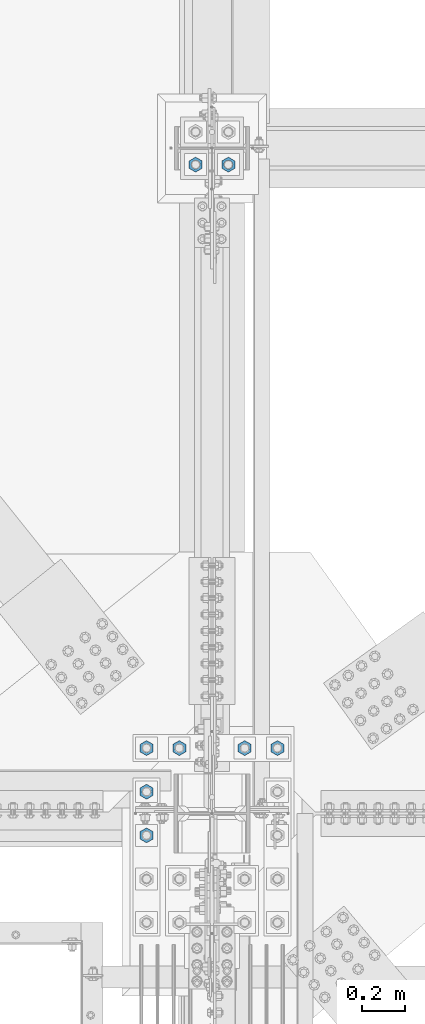
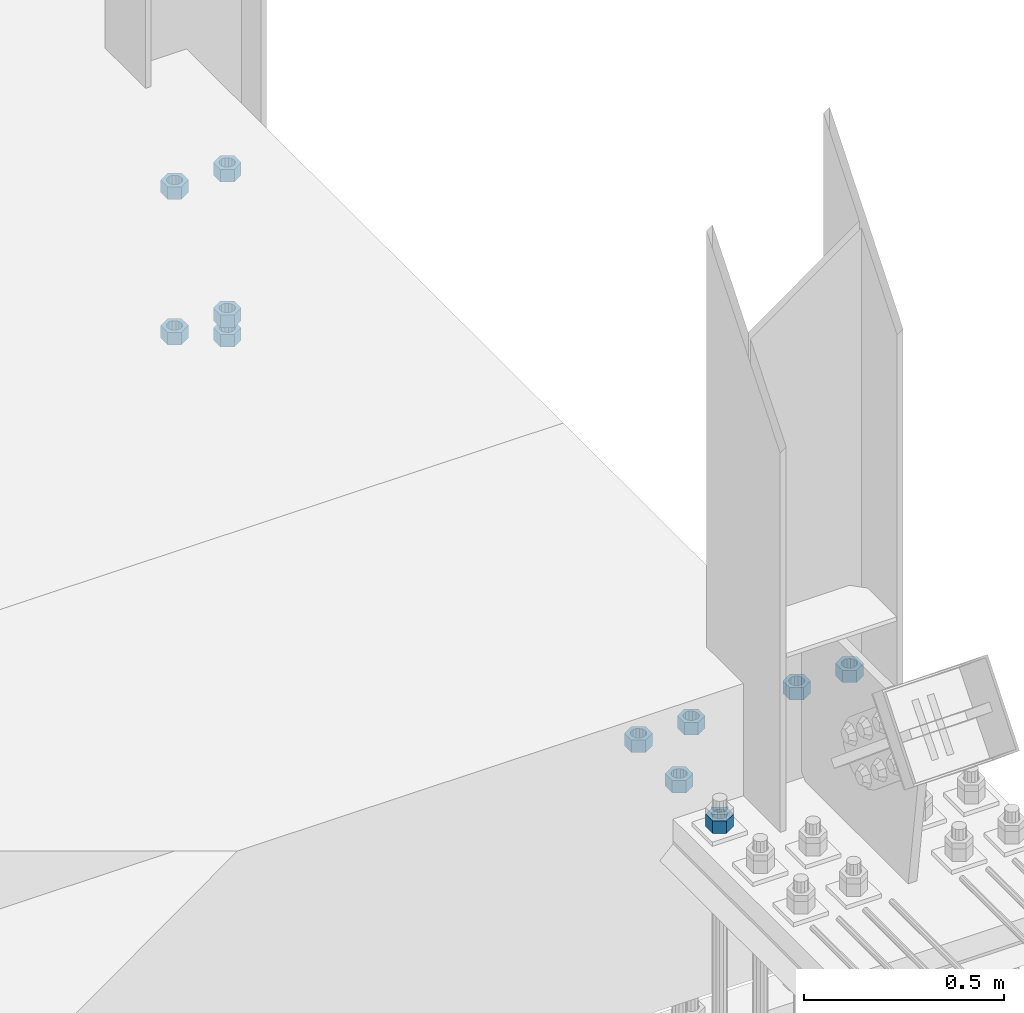
# One storey, part 1671 of 3843: 11 columns, 2 elements without a shape of their own.
"""IFC2X3 building model written with IfcOpenShell, lengths in millimetres."""

from ifc_helpers import new_model, si_unit, frame, origin_with_axes, place, context, subcontext, project, spatial, faceted_brep, material, type_object, element, aggregate, save


model = new_model("IFC2X3")

# Units and contexts
model_context = context("Model", 3, precision=1e-05, world=origin_with_axes())
body_context = subcontext(model_context, "Body", "Model", "MODEL_VIEW")
ifc_project = project(units=[si_unit("LENGTHUNIT", "METRE", prefix="MILLI"), si_unit("AREAUNIT", "SQUARE_METRE"), si_unit("VOLUMEUNIT", "CUBIC_METRE"), si_unit("MASSUNIT", "GRAM", prefix="KILO"), si_unit("TIMEUNIT", "SECOND"), si_unit("PLANEANGLEUNIT", "RADIAN"), si_unit("SOLIDANGLEUNIT", "STERADIAN"), si_unit("THERMODYNAMICTEMPERATUREUNIT", "DEGREE_CELSIUS"), si_unit("LUMINOUSINTENSITYUNIT", "LUMEN")], contexts=[model_context])

# Site, building, storey
site_placement = place(None, origin_with_axes())
site = spatial("IfcSite", under=ifc_project, at=site_placement, CompositionType="ELEMENT")
building_placement = place(site_placement, origin_with_axes())
building = spatial("IfcBuilding", under=site, at=building_placement, Name="Undefined", CompositionType="ELEMENT")
storey_placement = place(building_placement, origin_with_axes())
storey = spatial("IfcBuildingStorey", under=building, at=storey_placement, Name="Undefined", CompositionType="ELEMENT", Elevation=0.0)

# Assembly, columns
assembly_1_placement = place(storey_placement, origin_with_axes())
assembly_1 = element("IfcElementAssembly", 1, at=assembly_1_placement, inside=storey, Name="TEMPLATE", AssemblyPlace="NOTDEFINED", PredefinedType="RIGID_FRAME")
ifc_material_1 = material(Name="STEEL/A36")
column_type = type_object("IfcColumnType", Name="1-1/2_HEAVY_HEX_NUT", PredefinedType="NOTDEFINED")
column_1_placement = place(assembly_1_placement, frame((77089.0, 28638.5, 29705.3), z_axis=(1.0, 0.0, 0.0), x_axis=(0.0, 0.0, -1.0)))
column_1 = element("IfcColumn", 2, at=column_1_placement, type_object=column_type, material=ifc_material_1, Name="NUT", ObjectType="1-1/2_HEAVY_HEX_NUT", context=body_context, shape_type="Brep", body=[
    faceted_brep([(0.0, -34.9199981689453, 0.0), (0.0, -17.4599990844727, -30.25), (38.0999999999985, -17.4599990844727, -30.25), (38.0999999999985, -34.9199981689453, 0.0), (0.0, 17.4599990844727, -30.25), (38.0999999999985, 17.4599990844727, -30.25), (0.0, 34.9199981689453, 0.0), (38.0999999999985, 34.9199981689453, 0.0), (0.0, 17.4599990844727, 30.25), (38.0999999999985, 17.4599990844727, 30.25), (0.0, -17.4599990844727, 30.25), (38.0999999999985, -17.4599990844727, 30.25), (0.0, 0.0, 20.6399993896484), (0.0, 8.9553601105581, 18.5959968835959), (38.0999999999985, 8.9553601105581, 18.5959968835959), (38.0999999999985, 0.0, 20.6399993896484), (0.0, 16.1370013209525, 12.8688291298167), (38.0999999999985, 16.1370013209525, 12.8688291298167), (0.0, 20.1225115123816, 4.59283194104501), (38.0999999999985, 20.1225115123816, 4.59283194104501), (0.0, 20.1225115123816, -4.59283194104501), (38.0999999999985, 20.1225115123816, -4.59283194104501), (0.0, 16.1370013209525, -12.8688291298167), (38.0999999999985, 16.1370013209525, -12.8688291298167), (0.0, 8.9553601105581, -18.5959968835959), (38.0999999999985, 8.9553601105581, -18.5959968835959), (0.0, 0.0, -20.6399993896484), (38.0999999999985, 0.0, -20.6399993896484), (0.0, -8.9553601105581, -18.5959968835959), (38.0999999999985, -8.9553601105581, -18.5959968835959), (0.0, -16.1370013209525, -12.8688291298167), (38.0999999999985, -16.1370013209525, -12.8688291298167), (0.0, -20.1225115123816, -4.59283194104501), (38.0999999999985, -20.1225115123816, -4.59283194104501), (0.0, -20.1225115123816, 4.59283194104501), (38.0999999999985, -20.1225115123816, 4.59283194104501), (0.0, -16.1370013209525, 12.8688291298167), (38.0999999999985, -16.1370013209525, 12.8688291298167), (0.0, -8.9553601105581, 18.5959968835959), (38.0999999999985, -8.9553601105581, 18.5959968835959)], [[[0, 1, 2, 3]], [[1, 4, 5, 2]], [[4, 6, 7, 5]], [[6, 8, 9, 7]], [[8, 10, 11, 9]], [[10, 0, 3, 11]], [[12, 13, 14, 15]], [[13, 16, 17, 14]], [[16, 18, 19, 17]], [[18, 20, 21, 19]], [[20, 22, 23, 21]], [[22, 24, 25, 23]], [[24, 26, 27, 25]], [[26, 28, 29, 27]], [[28, 30, 31, 29]], [[30, 32, 33, 31]], [[32, 34, 35, 33]], [[34, 36, 37, 35]], [[36, 38, 39, 37]], [[38, 12, 15, 39]], [[5, 7, 9, 11, 3, 2], [17, 19, 21, 23, 25, 27, 29, 31, 33, 35, 37, 39, 15, 14]], [[10, 8, 6, 4, 1, 0], [38, 36, 34, 32, 30, 28, 26, 24, 22, 20, 18, 16, 13, 12]]]),
])
column_2_placement = place(assembly_1_placement, frame((76936.6, 28638.5, 29705.3), z_axis=(1.0, 0.0, 0.0), x_axis=(0.0, 0.0, -1.0)))
column_2 = element("IfcColumn", 3, at=column_2_placement, type_object=column_type, material=ifc_material_1, Name="NUT", ObjectType="1-1/2_HEAVY_HEX_NUT", context=body_context, shape_type="Brep", body=[
    faceted_brep([(0.0, -34.9199981689453, 0.0), (0.0, -17.4599990844727, -30.25), (38.0999999999985, -17.4599990844727, -30.25), (38.0999999999985, -34.9199981689453, 0.0), (0.0, 17.4599990844727, -30.25), (38.0999999999985, 17.4599990844727, -30.25), (0.0, 34.9199981689453, 0.0), (38.0999999999985, 34.9199981689453, 0.0), (0.0, 17.4599990844727, 30.25), (38.0999999999985, 17.4599990844727, 30.25), (0.0, -17.4599990844727, 30.25), (38.0999999999985, -17.4599990844727, 30.25), (0.0, 0.0, 20.6399993896484), (0.0, 8.9553601105581, 18.5959968835959), (38.0999999999985, 8.9553601105581, 18.5959968835959), (38.0999999999985, 0.0, 20.6399993896484), (0.0, 16.1370013209525, 12.8688291298167), (38.0999999999985, 16.1370013209525, 12.8688291298167), (0.0, 20.1225115123816, 4.59283194104501), (38.0999999999985, 20.1225115123816, 4.59283194104501), (0.0, 20.1225115123816, -4.59283194104501), (38.0999999999985, 20.1225115123816, -4.59283194104501), (0.0, 16.1370013209525, -12.8688291298167), (38.0999999999985, 16.1370013209525, -12.8688291298167), (0.0, 8.9553601105581, -18.5959968835959), (38.0999999999985, 8.9553601105581, -18.5959968835959), (0.0, 0.0, -20.6399993896484), (38.0999999999985, 0.0, -20.6399993896484), (0.0, -8.9553601105581, -18.5959968835959), (38.0999999999985, -8.9553601105581, -18.5959968835959), (0.0, -16.1370013209525, -12.8688291298167), (38.0999999999985, -16.1370013209525, -12.8688291298167), (0.0, -20.1225115123816, -4.59283194104501), (38.0999999999985, -20.1225115123816, -4.59283194104501), (0.0, -20.1225115123816, 4.59283194104501), (38.0999999999985, -20.1225115123816, 4.59283194104501), (0.0, -16.1370013209525, 12.8688291298167), (38.0999999999985, -16.1370013209525, 12.8688291298167), (0.0, -8.9553601105581, 18.5959968835959), (38.0999999999985, -8.9553601105581, 18.5959968835959)], [[[0, 1, 2, 3]], [[1, 4, 5, 2]], [[4, 6, 7, 5]], [[6, 8, 9, 7]], [[8, 10, 11, 9]], [[10, 0, 3, 11]], [[12, 13, 14, 15]], [[13, 16, 17, 14]], [[16, 18, 19, 17]], [[18, 20, 21, 19]], [[20, 22, 23, 21]], [[22, 24, 25, 23]], [[24, 26, 27, 25]], [[26, 28, 29, 27]], [[28, 30, 31, 29]], [[30, 32, 33, 31]], [[32, 34, 35, 33]], [[34, 36, 37, 35]], [[36, 38, 39, 37]], [[38, 12, 15, 39]], [[5, 7, 9, 11, 3, 2], [17, 19, 21, 23, 25, 27, 29, 31, 33, 35, 37, 39, 15, 14]], [[10, 8, 6, 4, 1, 0], [38, 36, 34, 32, 30, 28, 26, 24, 22, 20, 18, 16, 13, 12]]]),
])
column_3_placement = place(assembly_1_placement, frame((77089.0, 28638.5, 30149.8), z_axis=(1.0, 0.0, 0.0), x_axis=(0.0, 0.0, -1.0)))
column_3 = element("IfcColumn", 4, at=column_3_placement, type_object=column_type, material=ifc_material_1, Name="NUT", ObjectType="1-1/2_HEAVY_HEX_NUT", context=body_context, shape_type="Brep", body=[
    faceted_brep([(0.0, -34.9199981689453, 0.0), (0.0, -17.4599990844727, -30.25), (38.0999999999985, -17.4599990844727, -30.25), (38.0999999999985, -34.9199981689453, 0.0), (0.0, 17.4599990844727, -30.25), (38.0999999999985, 17.4599990844727, -30.25), (0.0, 34.9199981689453, 0.0), (38.0999999999985, 34.9199981689453, 0.0), (0.0, 17.4599990844727, 30.25), (38.0999999999985, 17.4599990844727, 30.25), (0.0, -17.4599990844727, 30.25), (38.0999999999985, -17.4599990844727, 30.25), (0.0, 0.0, 20.6399993896484), (0.0, 8.9553601105581, 18.5959968835959), (38.0999999999985, 8.9553601105581, 18.5959968835959), (38.0999999999985, 0.0, 20.6399993896484), (0.0, 16.1370013209525, 12.8688291298167), (38.0999999999985, 16.1370013209525, 12.8688291298167), (0.0, 20.1225115123816, 4.59283194104501), (38.0999999999985, 20.1225115123816, 4.59283194104501), (0.0, 20.1225115123816, -4.59283194104501), (38.0999999999985, 20.1225115123816, -4.59283194104501), (0.0, 16.1370013209525, -12.8688291298167), (38.0999999999985, 16.1370013209525, -12.8688291298167), (0.0, 8.9553601105581, -18.5959968835959), (38.0999999999985, 8.9553601105581, -18.5959968835959), (0.0, 0.0, -20.6399993896484), (38.0999999999985, 0.0, -20.6399993896484), (0.0, -8.9553601105581, -18.5959968835959), (38.0999999999985, -8.9553601105581, -18.5959968835959), (0.0, -16.1370013209525, -12.8688291298167), (38.0999999999985, -16.1370013209525, -12.8688291298167), (0.0, -20.1225115123816, -4.59283194104501), (38.0999999999985, -20.1225115123816, -4.59283194104501), (0.0, -20.1225115123816, 4.59283194104501), (38.0999999999985, -20.1225115123816, 4.59283194104501), (0.0, -16.1370013209525, 12.8688291298167), (38.0999999999985, -16.1370013209525, 12.8688291298167), (0.0, -8.9553601105581, 18.5959968835959), (38.0999999999985, -8.9553601105581, 18.5959968835959)], [[[0, 1, 2, 3]], [[1, 4, 5, 2]], [[4, 6, 7, 5]], [[6, 8, 9, 7]], [[8, 10, 11, 9]], [[10, 0, 3, 11]], [[12, 13, 14, 15]], [[13, 16, 17, 14]], [[16, 18, 19, 17]], [[18, 20, 21, 19]], [[20, 22, 23, 21]], [[22, 24, 25, 23]], [[24, 26, 27, 25]], [[26, 28, 29, 27]], [[28, 30, 31, 29]], [[30, 32, 33, 31]], [[32, 34, 35, 33]], [[34, 36, 37, 35]], [[36, 38, 39, 37]], [[38, 12, 15, 39]], [[5, 7, 9, 11, 3, 2], [17, 19, 21, 23, 25, 27, 29, 31, 33, 35, 37, 39, 15, 14]], [[10, 8, 6, 4, 1, 0], [38, 36, 34, 32, 30, 28, 26, 24, 22, 20, 18, 16, 13, 12]]]),
])
column_4_placement = place(assembly_1_placement, frame((77089.0, 28638.5, 29644.975), z_axis=(1.0, 0.0, 0.0), x_axis=(0.0, 0.0, -1.0)))
column_4 = element("IfcColumn", 5, at=column_4_placement, type_object=column_type, material=ifc_material_1, Name="NUT", ObjectType="1-1/2_HEAVY_HEX_NUT", context=body_context, shape_type="Brep", body=[
    faceted_brep([(0.0, -34.9199981689453, 0.0), (0.0, -17.4599990844727, -30.25), (38.0999999999985, -17.4599990844727, -30.25), (38.0999999999985, -34.9199981689453, 0.0), (0.0, 17.4599990844727, -30.25), (38.0999999999985, 17.4599990844727, -30.25), (0.0, 34.9199981689453, 0.0), (38.0999999999985, 34.9199981689453, 0.0), (0.0, 17.4599990844727, 30.25), (38.0999999999985, 17.4599990844727, 30.25), (0.0, -17.4599990844727, 30.25), (38.0999999999985, -17.4599990844727, 30.25), (0.0, 0.0, 20.6399993896484), (0.0, 8.9553601105581, 18.5959968835959), (38.0999999999985, 8.9553601105581, 18.5959968835959), (38.0999999999985, 0.0, 20.6399993896484), (0.0, 16.1370013209525, 12.8688291298167), (38.0999999999985, 16.1370013209525, 12.8688291298167), (0.0, 20.1225115123816, 4.59283194104501), (38.0999999999985, 20.1225115123816, 4.59283194104501), (0.0, 20.1225115123816, -4.59283194104501), (38.0999999999985, 20.1225115123816, -4.59283194104501), (0.0, 16.1370013209525, -12.8688291298167), (38.0999999999985, 16.1370013209525, -12.8688291298167), (0.0, 8.9553601105581, -18.5959968835959), (38.0999999999985, 8.9553601105581, -18.5959968835959), (0.0, 0.0, -20.6399993896484), (38.0999999999985, 0.0, -20.6399993896484), (0.0, -8.9553601105581, -18.5959968835959), (38.0999999999985, -8.9553601105581, -18.5959968835959), (0.0, -16.1370013209525, -12.8688291298167), (38.0999999999985, -16.1370013209525, -12.8688291298167), (0.0, -20.1225115123816, -4.59283194104501), (38.0999999999985, -20.1225115123816, -4.59283194104501), (0.0, -20.1225115123816, 4.59283194104501), (38.0999999999985, -20.1225115123816, 4.59283194104501), (0.0, -16.1370013209525, 12.8688291298167), (38.0999999999985, -16.1370013209525, 12.8688291298167), (0.0, -8.9553601105581, 18.5959968835959), (38.0999999999985, -8.9553601105581, 18.5959968835959)], [[[0, 1, 2, 3]], [[1, 4, 5, 2]], [[4, 6, 7, 5]], [[6, 8, 9, 7]], [[8, 10, 11, 9]], [[10, 0, 3, 11]], [[12, 13, 14, 15]], [[13, 16, 17, 14]], [[16, 18, 19, 17]], [[18, 20, 21, 19]], [[20, 22, 23, 21]], [[22, 24, 25, 23]], [[24, 26, 27, 25]], [[26, 28, 29, 27]], [[28, 30, 31, 29]], [[30, 32, 33, 31]], [[32, 34, 35, 33]], [[34, 36, 37, 35]], [[36, 38, 39, 37]], [[38, 12, 15, 39]], [[5, 7, 9, 11, 3, 2], [17, 19, 21, 23, 25, 27, 29, 31, 33, 35, 37, 39, 15, 14]], [[10, 8, 6, 4, 1, 0], [38, 36, 34, 32, 30, 28, 26, 24, 22, 20, 18, 16, 13, 12]]]),
])
column_5_placement = place(assembly_1_placement, frame((76936.6, 28638.5, 30149.8), z_axis=(1.0, 0.0, 0.0), x_axis=(0.0, 0.0, -1.0)))
column_5 = element("IfcColumn", 6, at=column_5_placement, type_object=column_type, material=ifc_material_1, Name="NUT", ObjectType="1-1/2_HEAVY_HEX_NUT", context=body_context, shape_type="Brep", body=[
    faceted_brep([(0.0, -34.9199981689453, 0.0), (0.0, -17.4599990844727, -30.25), (38.0999999999985, -17.4599990844727, -30.25), (38.0999999999985, -34.9199981689453, 0.0), (0.0, 17.4599990844727, -30.25), (38.0999999999985, 17.4599990844727, -30.25), (0.0, 34.9199981689453, 0.0), (38.0999999999985, 34.9199981689453, 0.0), (0.0, 17.4599990844727, 30.25), (38.0999999999985, 17.4599990844727, 30.25), (0.0, -17.4599990844727, 30.25), (38.0999999999985, -17.4599990844727, 30.25), (0.0, 0.0, 20.6399993896484), (0.0, 8.9553601105581, 18.5959968835959), (38.0999999999985, 8.9553601105581, 18.5959968835959), (38.0999999999985, 0.0, 20.6399993896484), (0.0, 16.1370013209525, 12.8688291298167), (38.0999999999985, 16.1370013209525, 12.8688291298167), (0.0, 20.1225115123816, 4.59283194104501), (38.0999999999985, 20.1225115123816, 4.59283194104501), (0.0, 20.1225115123816, -4.59283194104501), (38.0999999999985, 20.1225115123816, -4.59283194104501), (0.0, 16.1370013209525, -12.8688291298167), (38.0999999999985, 16.1370013209525, -12.8688291298167), (0.0, 8.9553601105581, -18.5959968835959), (38.0999999999985, 8.9553601105581, -18.5959968835959), (0.0, 0.0, -20.6399993896484), (38.0999999999985, 0.0, -20.6399993896484), (0.0, -8.9553601105581, -18.5959968835959), (38.0999999999985, -8.9553601105581, -18.5959968835959), (0.0, -16.1370013209525, -12.8688291298167), (38.0999999999985, -16.1370013209525, -12.8688291298167), (0.0, -20.1225115123816, -4.59283194104501), (38.0999999999985, -20.1225115123816, -4.59283194104501), (0.0, -20.1225115123816, 4.59283194104501), (38.0999999999985, -20.1225115123816, 4.59283194104501), (0.0, -16.1370013209525, 12.8688291298167), (38.0999999999985, -16.1370013209525, 12.8688291298167), (0.0, -8.9553601105581, 18.5959968835959), (38.0999999999985, -8.9553601105581, 18.5959968835959)], [[[0, 1, 2, 3]], [[1, 4, 5, 2]], [[4, 6, 7, 5]], [[6, 8, 9, 7]], [[8, 10, 11, 9]], [[10, 0, 3, 11]], [[12, 13, 14, 15]], [[13, 16, 17, 14]], [[16, 18, 19, 17]], [[18, 20, 21, 19]], [[20, 22, 23, 21]], [[22, 24, 25, 23]], [[24, 26, 27, 25]], [[26, 28, 29, 27]], [[28, 30, 31, 29]], [[30, 32, 33, 31]], [[32, 34, 35, 33]], [[34, 36, 37, 35]], [[36, 38, 39, 37]], [[38, 12, 15, 39]], [[5, 7, 9, 11, 3, 2], [17, 19, 21, 23, 25, 27, 29, 31, 33, 35, 37, 39, 15, 14]], [[10, 8, 6, 4, 1, 0], [38, 36, 34, 32, 30, 28, 26, 24, 22, 20, 18, 16, 13, 12]]]),
])
aggregate(assembly_1, [column_1, column_2, column_3, column_4, column_5])

assembly_2_placement = place(storey_placement, origin_with_axes())
assembly_2 = element("IfcElementAssembly", 7, at=assembly_2_placement, inside=storey, Name="TEMPLATE", AssemblyPlace="NOTDEFINED", PredefinedType="RIGID_FRAME")
ifc_material_2 = material(Name="STEEL/A572-50")
column_6_placement = place(assembly_2_placement, frame((77317.6, 25920.7, 30187.9), z_axis=(-1.0, 0.0, 0.0), x_axis=(0.0, 0.0, -1.0)))
column_6 = element("IfcColumn", 8, at=column_6_placement, type_object=column_type, material=ifc_material_2, Name="NUT", ObjectType="1-1/2_HEAVY_HEX_NUT", context=body_context, shape_type="Brep", body=[
    faceted_brep([(0.0, -34.9199981689453, 0.0), (0.0, -17.4599990844727, -30.25), (38.0999999999985, -17.4599990844727, -30.25), (38.0999999999985, -34.9199981689453, 0.0), (0.0, 17.4599990844727, -30.25), (38.0999999999985, 17.4599990844727, -30.25), (0.0, 34.9199981689453, 0.0), (38.0999999999985, 34.9199981689453, 0.0), (0.0, 17.4599990844727, 30.25), (38.0999999999985, 17.4599990844727, 30.25), (0.0, -17.4599990844727, 30.25), (38.0999999999985, -17.4599990844727, 30.25), (0.0, 0.0, 20.6399993896484), (0.0, 8.9553601105581, 18.5959968835959), (38.0999999999985, 8.9553601105581, 18.5959968835959), (38.0999999999985, 0.0, 20.6399993896484), (0.0, 16.1370013209525, 12.8688291298167), (38.0999999999985, 16.1370013209525, 12.8688291298167), (0.0, 20.1225115123816, 4.59283194104501), (38.0999999999985, 20.1225115123816, 4.59283194104501), (0.0, 20.1225115123816, -4.59283194104501), (38.0999999999985, 20.1225115123816, -4.59283194104501), (0.0, 16.1370013209525, -12.8688291298167), (38.0999999999985, 16.1370013209525, -12.8688291298167), (0.0, 8.9553601105581, -18.5959968835959), (38.0999999999985, 8.9553601105581, -18.5959968835959), (0.0, 0.0, -20.6399993896484), (38.0999999999985, 0.0, -20.6399993896484), (0.0, -8.9553601105581, -18.5959968835959), (38.0999999999985, -8.9553601105581, -18.5959968835959), (0.0, -16.1370013209525, -12.8688291298167), (38.0999999999985, -16.1370013209525, -12.8688291298167), (0.0, -20.1225115123816, -4.59283194104501), (38.0999999999985, -20.1225115123816, -4.59283194104501), (0.0, -20.1225115123816, 4.59283194104501), (38.0999999999985, -20.1225115123816, 4.59283194104501), (0.0, -16.1370013209525, 12.8688291298167), (38.0999999999985, -16.1370013209525, 12.8688291298167), (0.0, -8.9553601105581, 18.5959968835959), (38.0999999999985, -8.9553601105581, 18.5959968835959)], [[[0, 1, 2, 3]], [[1, 4, 5, 2]], [[4, 6, 7, 5]], [[6, 8, 9, 7]], [[8, 10, 11, 9]], [[10, 0, 3, 11]], [[12, 13, 14, 15]], [[13, 16, 17, 14]], [[16, 18, 19, 17]], [[18, 20, 21, 19]], [[20, 22, 23, 21]], [[22, 24, 25, 23]], [[24, 26, 27, 25]], [[26, 28, 29, 27]], [[28, 30, 31, 29]], [[30, 32, 33, 31]], [[32, 34, 35, 33]], [[34, 36, 37, 35]], [[36, 38, 39, 37]], [[38, 12, 15, 39]], [[5, 7, 9, 11, 3, 2], [17, 19, 21, 23, 25, 27, 29, 31, 33, 35, 37, 39, 15, 14]], [[10, 8, 6, 4, 1, 0], [38, 36, 34, 32, 30, 28, 26, 24, 22, 20, 18, 16, 13, 12]]]),
])
column_7_placement = place(assembly_2_placement, frame((77165.2, 25920.7, 30187.9), z_axis=(-1.0, 0.0, 0.0), x_axis=(0.0, 0.0, -1.0)))
column_7 = element("IfcColumn", 9, at=column_7_placement, type_object=column_type, material=ifc_material_2, Name="NUT", ObjectType="1-1/2_HEAVY_HEX_NUT", context=body_context, shape_type="Brep", body=[
    faceted_brep([(0.0, -34.9199981689453, 0.0), (0.0, -17.4599990844727, -30.25), (38.0999999999985, -17.4599990844727, -30.25), (38.0999999999985, -34.9199981689453, 0.0), (0.0, 17.4599990844727, -30.25), (38.0999999999985, 17.4599990844727, -30.25), (0.0, 34.9199981689453, 0.0), (38.0999999999985, 34.9199981689453, 0.0), (0.0, 17.4599990844727, 30.25), (38.0999999999985, 17.4599990844727, 30.25), (0.0, -17.4599990844727, 30.25), (38.0999999999985, -17.4599990844727, 30.25), (0.0, 0.0, 20.6399993896484), (0.0, 8.9553601105581, 18.5959968835959), (38.0999999999985, 8.9553601105581, 18.5959968835959), (38.0999999999985, 0.0, 20.6399993896484), (0.0, 16.1370013209525, 12.8688291298167), (38.0999999999985, 16.1370013209525, 12.8688291298167), (0.0, 20.1225115123816, 4.59283194104501), (38.0999999999985, 20.1225115123816, 4.59283194104501), (0.0, 20.1225115123816, -4.59283194104501), (38.0999999999985, 20.1225115123816, -4.59283194104501), (0.0, 16.1370013209525, -12.8688291298167), (38.0999999999985, 16.1370013209525, -12.8688291298167), (0.0, 8.9553601105581, -18.5959968835959), (38.0999999999985, 8.9553601105581, -18.5959968835959), (0.0, 0.0, -20.6399993896484), (38.0999999999985, 0.0, -20.6399993896484), (0.0, -8.9553601105581, -18.5959968835959), (38.0999999999985, -8.9553601105581, -18.5959968835959), (0.0, -16.1370013209525, -12.8688291298167), (38.0999999999985, -16.1370013209525, -12.8688291298167), (0.0, -20.1225115123816, -4.59283194104501), (38.0999999999985, -20.1225115123816, -4.59283194104501), (0.0, -20.1225115123816, 4.59283194104501), (38.0999999999985, -20.1225115123816, 4.59283194104501), (0.0, -16.1370013209525, 12.8688291298167), (38.0999999999985, -16.1370013209525, 12.8688291298167), (0.0, -8.9553601105581, 18.5959968835959), (38.0999999999985, -8.9553601105581, 18.5959968835959)], [[[0, 1, 2, 3]], [[1, 4, 5, 2]], [[4, 6, 7, 5]], [[6, 8, 9, 7]], [[8, 10, 11, 9]], [[10, 0, 3, 11]], [[12, 13, 14, 15]], [[13, 16, 17, 14]], [[16, 18, 19, 17]], [[18, 20, 21, 19]], [[20, 22, 23, 21]], [[22, 24, 25, 23]], [[24, 26, 27, 25]], [[26, 28, 29, 27]], [[28, 30, 31, 29]], [[30, 32, 33, 31]], [[32, 34, 35, 33]], [[34, 36, 37, 35]], [[36, 38, 39, 37]], [[38, 12, 15, 39]], [[5, 7, 9, 11, 3, 2], [17, 19, 21, 23, 25, 27, 29, 31, 33, 35, 37, 39, 15, 14]], [[10, 8, 6, 4, 1, 0], [38, 36, 34, 32, 30, 28, 26, 24, 22, 20, 18, 16, 13, 12]]]),
])
column_8_placement = place(assembly_2_placement, frame((76860.4, 25920.7, 30187.9), z_axis=(-1.0, 0.0, 0.0), x_axis=(0.0, 0.0, -1.0)))
column_8 = element("IfcColumn", 10, at=column_8_placement, type_object=column_type, material=ifc_material_2, Name="NUT", ObjectType="1-1/2_HEAVY_HEX_NUT", context=body_context, shape_type="Brep", body=[
    faceted_brep([(0.0, -34.9199981689453, 0.0), (0.0, -17.4599990844727, -30.25), (38.0999999999985, -17.4599990844727, -30.25), (38.0999999999985, -34.9199981689453, 0.0), (0.0, 17.4599990844727, -30.25), (38.0999999999985, 17.4599990844727, -30.25), (0.0, 34.9199981689453, 0.0), (38.0999999999985, 34.9199981689453, 0.0), (0.0, 17.4599990844727, 30.25), (38.0999999999985, 17.4599990844727, 30.25), (0.0, -17.4599990844727, 30.25), (38.0999999999985, -17.4599990844727, 30.25), (0.0, 0.0, 20.6399993896484), (0.0, 8.9553601105581, 18.5959968835959), (38.0999999999985, 8.9553601105581, 18.5959968835959), (38.0999999999985, 0.0, 20.6399993896484), (0.0, 16.1370013209525, 12.8688291298167), (38.0999999999985, 16.1370013209525, 12.8688291298167), (0.0, 20.1225115123816, 4.59283194104501), (38.0999999999985, 20.1225115123816, 4.59283194104501), (0.0, 20.1225115123816, -4.59283194104501), (38.0999999999985, 20.1225115123816, -4.59283194104501), (0.0, 16.1370013209525, -12.8688291298167), (38.0999999999985, 16.1370013209525, -12.8688291298167), (0.0, 8.9553601105581, -18.5959968835959), (38.0999999999985, 8.9553601105581, -18.5959968835959), (0.0, 0.0, -20.6399993896484), (38.0999999999985, 0.0, -20.6399993896484), (0.0, -8.9553601105581, -18.5959968835959), (38.0999999999985, -8.9553601105581, -18.5959968835959), (0.0, -16.1370013209525, -12.8688291298167), (38.0999999999985, -16.1370013209525, -12.8688291298167), (0.0, -20.1225115123816, -4.59283194104501), (38.0999999999985, -20.1225115123816, -4.59283194104501), (0.0, -20.1225115123816, 4.59283194104501), (38.0999999999985, -20.1225115123816, 4.59283194104501), (0.0, -16.1370013209525, 12.8688291298167), (38.0999999999985, -16.1370013209525, 12.8688291298167), (0.0, -8.9553601105581, 18.5959968835959), (38.0999999999985, -8.9553601105581, 18.5959968835959)], [[[0, 1, 2, 3]], [[1, 4, 5, 2]], [[4, 6, 7, 5]], [[6, 8, 9, 7]], [[8, 10, 11, 9]], [[10, 0, 3, 11]], [[12, 13, 14, 15]], [[13, 16, 17, 14]], [[16, 18, 19, 17]], [[18, 20, 21, 19]], [[20, 22, 23, 21]], [[22, 24, 25, 23]], [[24, 26, 27, 25]], [[26, 28, 29, 27]], [[28, 30, 31, 29]], [[30, 32, 33, 31]], [[32, 34, 35, 33]], [[34, 36, 37, 35]], [[36, 38, 39, 37]], [[38, 12, 15, 39]], [[5, 7, 9, 11, 3, 2], [17, 19, 21, 23, 25, 27, 29, 31, 33, 35, 37, 39, 15, 14]], [[10, 8, 6, 4, 1, 0], [38, 36, 34, 32, 30, 28, 26, 24, 22, 20, 18, 16, 13, 12]]]),
])
column_9_placement = place(assembly_2_placement, frame((76708.0, 25514.3, 30187.9), z_axis=(1.0, 0.0, 0.0), x_axis=(0.0, 0.0, -1.0)))
column_9 = element("IfcColumn", 11, at=column_9_placement, type_object=column_type, material=ifc_material_2, Name="NUT", ObjectType="1-1/2_HEAVY_HEX_NUT", context=body_context, shape_type="Brep", body=[
    faceted_brep([(0.0, -34.9199981689453, 0.0), (0.0, -17.4599990844727, -30.25), (38.0999999999985, -17.4599990844727, -30.25), (38.0999999999985, -34.9199981689453, 0.0), (0.0, 17.4599990844727, -30.25), (38.0999999999985, 17.4599990844727, -30.25), (0.0, 34.9199981689453, 0.0), (38.0999999999985, 34.9199981689453, 0.0), (0.0, 17.4599990844727, 30.25), (38.0999999999985, 17.4599990844727, 30.25), (0.0, -17.4599990844727, 30.25), (38.0999999999985, -17.4599990844727, 30.25), (0.0, 0.0, 20.6399993896484), (0.0, 8.9553601105581, 18.5959968835959), (38.0999999999985, 8.9553601105581, 18.5959968835959), (38.0999999999985, 0.0, 20.6399993896484), (0.0, 16.1370013209525, 12.8688291298167), (38.0999999999985, 16.1370013209525, 12.8688291298167), (0.0, 20.1225115123816, 4.59283194104501), (38.0999999999985, 20.1225115123816, 4.59283194104501), (0.0, 20.1225115123816, -4.59283194104501), (38.0999999999985, 20.1225115123816, -4.59283194104501), (0.0, 16.1370013209525, -12.8688291298167), (38.0999999999985, 16.1370013209525, -12.8688291298167), (0.0, 8.9553601105581, -18.5959968835959), (38.0999999999985, 8.9553601105581, -18.5959968835959), (0.0, 0.0, -20.6399993896484), (38.0999999999985, 0.0, -20.6399993896484), (0.0, -8.9553601105581, -18.5959968835959), (38.0999999999985, -8.9553601105581, -18.5959968835959), (0.0, -16.1370013209525, -12.8688291298167), (38.0999999999985, -16.1370013209525, -12.8688291298167), (0.0, -20.1225115123816, -4.59283194104501), (38.0999999999985, -20.1225115123816, -4.59283194104501), (0.0, -20.1225115123816, 4.59283194104501), (38.0999999999985, -20.1225115123816, 4.59283194104501), (0.0, -16.1370013209525, 12.8688291298167), (38.0999999999985, -16.1370013209525, 12.8688291298167), (0.0, -8.9553601105581, 18.5959968835959), (38.0999999999985, -8.9553601105581, 18.5959968835959)], [[[0, 1, 2, 3]], [[1, 4, 5, 2]], [[4, 6, 7, 5]], [[6, 8, 9, 7]], [[8, 10, 11, 9]], [[10, 0, 3, 11]], [[12, 13, 14, 15]], [[13, 16, 17, 14]], [[16, 18, 19, 17]], [[18, 20, 21, 19]], [[20, 22, 23, 21]], [[22, 24, 25, 23]], [[24, 26, 27, 25]], [[26, 28, 29, 27]], [[28, 30, 31, 29]], [[30, 32, 33, 31]], [[32, 34, 35, 33]], [[34, 36, 37, 35]], [[36, 38, 39, 37]], [[38, 12, 15, 39]], [[5, 7, 9, 11, 3, 2], [17, 19, 21, 23, 25, 27, 29, 31, 33, 35, 37, 39, 15, 14]], [[10, 8, 6, 4, 1, 0], [38, 36, 34, 32, 30, 28, 26, 24, 22, 20, 18, 16, 13, 12]]]),
])
column_10_placement = place(assembly_2_placement, frame((76708.0, 25717.5, 30187.9), z_axis=(-1.0, 0.0, 0.0), x_axis=(0.0, 0.0, -1.0)))
column_10 = element("IfcColumn", 12, at=column_10_placement, type_object=column_type, material=ifc_material_2, Name="NUT", ObjectType="1-1/2_HEAVY_HEX_NUT", context=body_context, shape_type="Brep", body=[
    faceted_brep([(0.0, -34.9199981689453, 0.0), (0.0, -17.4599990844727, -30.25), (38.0999999999985, -17.4599990844727, -30.25), (38.0999999999985, -34.9199981689453, 0.0), (0.0, 17.4599990844727, -30.25), (38.0999999999985, 17.4599990844727, -30.25), (0.0, 34.9199981689453, 0.0), (38.0999999999985, 34.9199981689453, 0.0), (0.0, 17.4599990844727, 30.25), (38.0999999999985, 17.4599990844727, 30.25), (0.0, -17.4599990844727, 30.25), (38.0999999999985, -17.4599990844727, 30.25), (0.0, 0.0, 20.6399993896484), (0.0, 8.9553601105581, 18.5959968835959), (38.0999999999985, 8.9553601105581, 18.5959968835959), (38.0999999999985, 0.0, 20.6399993896484), (0.0, 16.1370013209525, 12.8688291298167), (38.0999999999985, 16.1370013209525, 12.8688291298167), (0.0, 20.1225115123816, 4.59283194104501), (38.0999999999985, 20.1225115123816, 4.59283194104501), (0.0, 20.1225115123816, -4.59283194104501), (38.0999999999985, 20.1225115123816, -4.59283194104501), (0.0, 16.1370013209525, -12.8688291298167), (38.0999999999985, 16.1370013209525, -12.8688291298167), (0.0, 8.9553601105581, -18.5959968835959), (38.0999999999985, 8.9553601105581, -18.5959968835959), (0.0, 0.0, -20.6399993896484), (38.0999999999985, 0.0, -20.6399993896484), (0.0, -8.9553601105581, -18.5959968835959), (38.0999999999985, -8.9553601105581, -18.5959968835959), (0.0, -16.1370013209525, -12.8688291298167), (38.0999999999985, -16.1370013209525, -12.8688291298167), (0.0, -20.1225115123816, -4.59283194104501), (38.0999999999985, -20.1225115123816, -4.59283194104501), (0.0, -20.1225115123816, 4.59283194104501), (38.0999999999985, -20.1225115123816, 4.59283194104501), (0.0, -16.1370013209525, 12.8688291298167), (38.0999999999985, -16.1370013209525, 12.8688291298167), (0.0, -8.9553601105581, 18.5959968835959), (38.0999999999985, -8.9553601105581, 18.5959968835959)], [[[0, 1, 2, 3]], [[1, 4, 5, 2]], [[4, 6, 7, 5]], [[6, 8, 9, 7]], [[8, 10, 11, 9]], [[10, 0, 3, 11]], [[12, 13, 14, 15]], [[13, 16, 17, 14]], [[16, 18, 19, 17]], [[18, 20, 21, 19]], [[20, 22, 23, 21]], [[22, 24, 25, 23]], [[24, 26, 27, 25]], [[26, 28, 29, 27]], [[28, 30, 31, 29]], [[30, 32, 33, 31]], [[32, 34, 35, 33]], [[34, 36, 37, 35]], [[36, 38, 39, 37]], [[38, 12, 15, 39]], [[5, 7, 9, 11, 3, 2], [17, 19, 21, 23, 25, 27, 29, 31, 33, 35, 37, 39, 15, 14]], [[10, 8, 6, 4, 1, 0], [38, 36, 34, 32, 30, 28, 26, 24, 22, 20, 18, 16, 13, 12]]]),
])
column_11_placement = place(assembly_2_placement, frame((76708.0, 25920.7, 30187.9), z_axis=(-1.0, 0.0, 0.0), x_axis=(0.0, 0.0, -1.0)))
column_11 = element("IfcColumn", 13, at=column_11_placement, type_object=column_type, material=ifc_material_2, Name="NUT", ObjectType="1-1/2_HEAVY_HEX_NUT", context=body_context, shape_type="Brep", body=[
    faceted_brep([(0.0, -34.9199981689453, 0.0), (0.0, -17.4599990844727, -30.25), (38.0999999999985, -17.4599990844727, -30.25), (38.0999999999985, -34.9199981689453, 0.0), (0.0, 17.4599990844727, -30.25), (38.0999999999985, 17.4599990844727, -30.25), (0.0, 34.9199981689453, 0.0), (38.0999999999985, 34.9199981689453, 0.0), (0.0, 17.4599990844727, 30.25), (38.0999999999985, 17.4599990844727, 30.25), (0.0, -17.4599990844727, 30.25), (38.0999999999985, -17.4599990844727, 30.25), (0.0, 0.0, 20.6399993896484), (0.0, 8.9553601105581, 18.5959968835959), (38.0999999999985, 8.9553601105581, 18.5959968835959), (38.0999999999985, 0.0, 20.6399993896484), (0.0, 16.1370013209525, 12.8688291298167), (38.0999999999985, 16.1370013209525, 12.8688291298167), (0.0, 20.1225115123816, 4.59283194104501), (38.0999999999985, 20.1225115123816, 4.59283194104501), (0.0, 20.1225115123816, -4.59283194104501), (38.0999999999985, 20.1225115123816, -4.59283194104501), (0.0, 16.1370013209525, -12.8688291298167), (38.0999999999985, 16.1370013209525, -12.8688291298167), (0.0, 8.9553601105581, -18.5959968835959), (38.0999999999985, 8.9553601105581, -18.5959968835959), (0.0, 0.0, -20.6399993896484), (38.0999999999985, 0.0, -20.6399993896484), (0.0, -8.9553601105581, -18.5959968835959), (38.0999999999985, -8.9553601105581, -18.5959968835959), (0.0, -16.1370013209525, -12.8688291298167), (38.0999999999985, -16.1370013209525, -12.8688291298167), (0.0, -20.1225115123816, -4.59283194104501), (38.0999999999985, -20.1225115123816, -4.59283194104501), (0.0, -20.1225115123816, 4.59283194104501), (38.0999999999985, -20.1225115123816, 4.59283194104501), (0.0, -16.1370013209525, 12.8688291298167), (38.0999999999985, -16.1370013209525, 12.8688291298167), (0.0, -8.9553601105581, 18.5959968835959), (38.0999999999985, -8.9553601105581, 18.5959968835959)], [[[0, 1, 2, 3]], [[1, 4, 5, 2]], [[4, 6, 7, 5]], [[6, 8, 9, 7]], [[8, 10, 11, 9]], [[10, 0, 3, 11]], [[12, 13, 14, 15]], [[13, 16, 17, 14]], [[16, 18, 19, 17]], [[18, 20, 21, 19]], [[20, 22, 23, 21]], [[22, 24, 25, 23]], [[24, 26, 27, 25]], [[26, 28, 29, 27]], [[28, 30, 31, 29]], [[30, 32, 33, 31]], [[32, 34, 35, 33]], [[34, 36, 37, 35]], [[36, 38, 39, 37]], [[38, 12, 15, 39]], [[5, 7, 9, 11, 3, 2], [17, 19, 21, 23, 25, 27, 29, 31, 33, 35, 37, 39, 15, 14]], [[10, 8, 6, 4, 1, 0], [38, 36, 34, 32, 30, 28, 26, 24, 22, 20, 18, 16, 13, 12]]]),
])
aggregate(assembly_2, [column_6, column_7, column_8, column_9, column_10, column_11])

save(model, "model.ifc")
